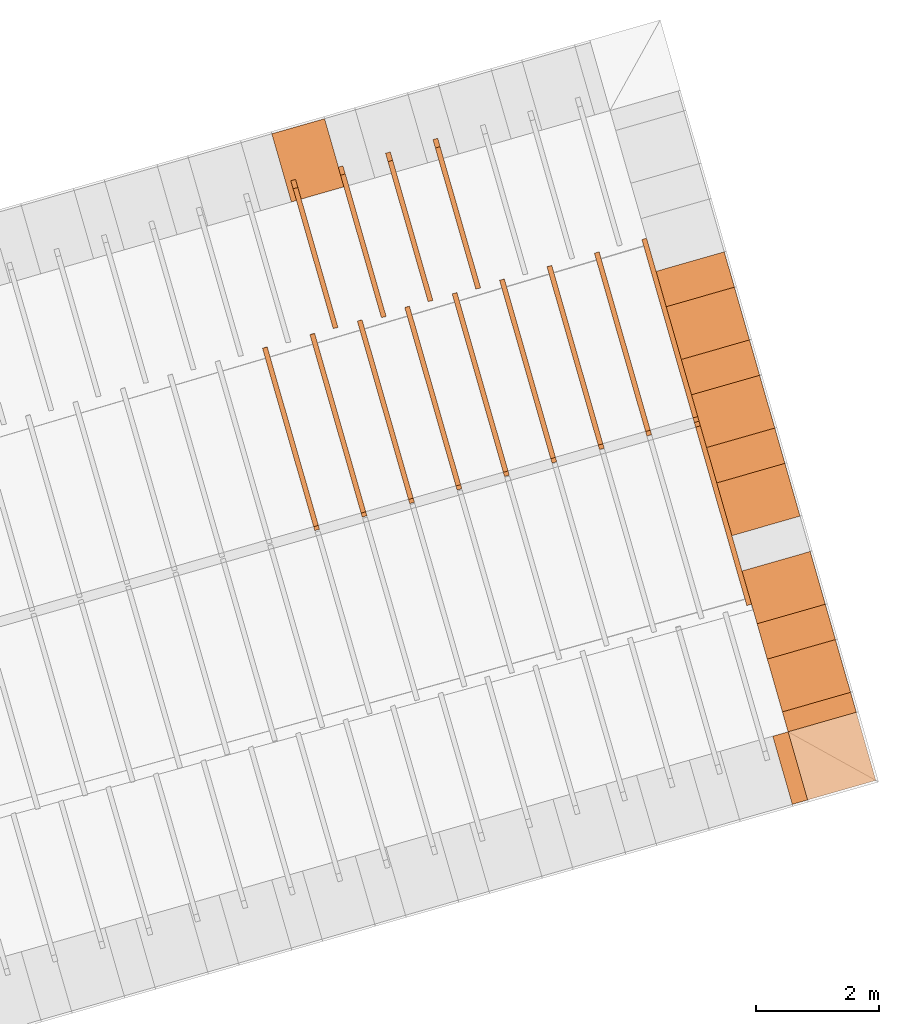
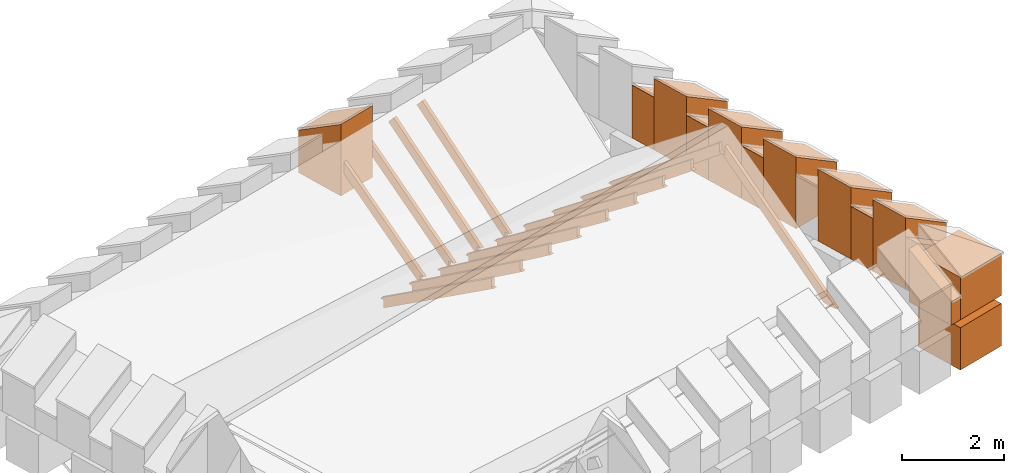
# One storey, part 9 of 10: 28 proxies.
"""IFC4 building model written with IfcOpenShell, lengths in metres."""

from ifc_helpers import new_model, entity, si_unit, converted_unit, derived_unit, direction, frame, origin_with_axes, place, context, subcontext, project, spatial, polygons, material, type_object, element, save


model = new_model("IFC4")

# Units and contexts
model_context = context("Model", 3, precision=1e-05, world=origin_with_axes(), true_north=direction((0.0, 1.0)))
body_context = subcontext(model_context, "Body", "Model", "MODEL_VIEW")
ifc_project = project(units=[si_unit("LENGTHUNIT", "METRE"), si_unit("AREAUNIT", "SQUARE_METRE"), si_unit("VOLUMEUNIT", "CUBIC_METRE"), converted_unit("PLANEANGLEUNIT", "DEGREE", entity("IfcPlaneAngleMeasure", 0.0174532925199433), si_unit("PLANEANGLEUNIT", "RADIAN"), dimensions=[0, 0, 0, 0, 0, 0, 0]), converted_unit("TIMEUNIT", "Year", entity("IfcTimeMeasure", 31557600.0), si_unit("TIMEUNIT", "SECOND"), dimensions=[0, 0, 1, 0, 0, 0, 0]), si_unit("MASSUNIT", "GRAM", prefix="KILO"), si_unit("THERMODYNAMICTEMPERATUREUNIT", "DEGREE_CELSIUS"), si_unit("LUMINOUSINTENSITYUNIT", "LUMEN"), si_unit("ENERGYUNIT", "JOULE", prefix="MEGA"), derived_unit("THERMALCONDUCTANCEUNIT", [(si_unit("POWERUNIT", "WATT"), 1), (si_unit("LENGTHUNIT", "METRE"), -1), (si_unit("THERMODYNAMICTEMPERATUREUNIT", "KELVIN"), -1)]), derived_unit("SPECIFICHEATCAPACITYUNIT", [(si_unit("ENERGYUNIT", "JOULE"), 1), (si_unit("MASSUNIT", "GRAM", prefix="KILO"), -1), (si_unit("THERMODYNAMICTEMPERATUREUNIT", "KELVIN"), -1)]), derived_unit("MASSDENSITYUNIT", [(si_unit("MASSUNIT", "GRAM", prefix="KILO"), 1), (si_unit("VOLUMEUNIT", "CUBIC_METRE"), -1)])], contexts=[model_context])

# Site, building, storey
site_placement = place(None, frame((0.0, 0.0, 0.0), z_axis=(0.0, 0.0, 1.0), x_axis=(0.9612616959383189, 0.2756373558169991, 0.0)))
site = spatial("IfcSite", under=ifc_project, at=site_placement, CompositionType="ELEMENT")
building_placement = place(site_placement, origin_with_axes())
building = spatial("IfcBuilding", under=site, at=building_placement, CompositionType="ELEMENT")
storey_placement = place(building_placement, frame((0.0, 0.0, 11.0), z_axis=(0.0, 0.0, 1.0), x_axis=(1.0, 0.0, 0.0)))
storey = spatial("IfcBuildingStorey", under=building, at=storey_placement, Name="Dach", CompositionType="ELEMENT", Elevation=11.0)

# Proxies
ifc_material_1 = material()
building_element_proxy_type_1 = type_object("IfcBuildingElementProxyType", PredefinedType="NOTDEFINED")
proxy_1_placement = place(storey_placement, frame((-32.67063236374476, 25.87969375484247, -11.3285), z_axis=(0.0, 0.0, 1.0), x_axis=(-1.0, 0.0, 0.0)))
element("IfcBuildingElementProxy", 1, at=proxy_1_placement, inside=storey, type_object=building_element_proxy_type_1, material=ifc_material_1, Name="008", PredefinedType="NOTDEFINED", context=body_context, shape_type="Tessellation", body=[
    polygons([(-57.83241932296884, 7.390572951635179, 12.28518703684454), (-57.83241932296884, 9.787341089745905, 10.39696107503057), (-57.83241932296884, 9.787341089745905, 10.60205325203643), (-57.83241932296884, 9.882514153140576, 10.60205325203643), (-57.83241932296884, 7.526718754969064, 12.458), (-57.91241932296884, 7.390572951635179, 12.28518703684454), (-57.91241932296884, 9.787341089745905, 10.39696107503057), (-57.91241932296884, 9.787341089745905, 10.59617545422803), (-57.91241932296884, 9.889974975517944, 10.59617545422803), (-57.91241932296884, 7.526718754969064, 12.458)], [[[1, 2, 3, 4, 5]], [[1, 6, 7, 2]], [[2, 7, 8, 3]], [[3, 8, 9, 4]], [[4, 9, 10, 5]], [[5, 10, 6, 1]], [[6, 10, 9, 8, 7]]], closed=True),
])
proxy_2_placement = place(storey_placement, frame((-32.67063236374476, 25.87969375484247, -11.3285), z_axis=(0.0, 0.0, 1.0), x_axis=(-1.0, 0.0, 0.0)))
element("IfcBuildingElementProxy", 2, at=proxy_2_placement, inside=storey, type_object=building_element_proxy_type_1, material=ifc_material_1, Name="008", PredefinedType="NOTDEFINED", context=body_context, shape_type="Tessellation", body=[
    polygons([(-58.63241932296884, 7.389549320189349, 12.28599841232647), (-58.63241932296884, 9.787341089745905, 10.37378500663502), (-58.63241932296884, 9.787341089745905, 10.54327527395242), (-58.63241932296884, 9.9276595576109, 10.54327527395242), (-58.63241932296884, 7.526718754969065, 12.458), (-58.71241932296884, 7.389549320189349, 12.28599841232647), (-58.71241932296884, 9.787341089745905, 10.37378500663502), (-58.71241932296884, 9.787341089745905, 10.53739747614402), (-58.71241932296884, 9.935029935397266, 10.53739747614402), (-58.71241932296884, 7.526718754969065, 12.458)], [[[1, 2, 3, 4, 5]], [[1, 6, 7, 2]], [[2, 7, 8, 3]], [[3, 8, 9, 4]], [[4, 9, 10, 5]], [[5, 10, 6, 1]], [[10, 9, 8, 7, 6]]], closed=True),
])
proxy_3_placement = place(storey_placement, frame((-32.67063236374476, 25.87969375484247, -11.3285), z_axis=(0.0, 0.0, 1.0), x_axis=(-1.0, 0.0, 0.0)))
element("IfcBuildingElementProxy", 3, at=proxy_3_placement, inside=storey, type_object=building_element_proxy_type_1, material=ifc_material_1, Name="008", PredefinedType="NOTDEFINED", context=body_context, shape_type="Tessellation", body=[
    polygons([(-59.43241932296884, 7.385575854858428, 12.28924372086243), (-59.43241932296885, 9.787341089745906, 10.28047632939507), (-59.43241932296885, 9.787341089745905, 10.48449729586842), (-59.43241932296884, 9.886320073605198, 10.48449729586842), (-59.43241932296884, 7.526718754969064, 12.458), (-59.51241932296884, 7.385575854858428, 12.28924372086243), (-59.51241932296885, 9.787341089745906, 10.28047632939507), (-59.51241932296885, 9.787341089745905, 10.47861949806002), (-59.51241932296884, 9.893347811358149, 10.47861949806002), (-59.51241932296884, 7.526718754969064, 12.458)], [[[1, 2, 3, 4, 5]], [[1, 6, 7, 2]], [[2, 7, 8, 3]], [[3, 8, 9, 4]], [[4, 9, 10, 5]], [[5, 10, 6, 1]], [[6, 10, 9, 8, 7]]], closed=True),
])
proxy_4_placement = place(storey_placement, frame((-32.67063236374476, 25.87969375484247, -11.3285), z_axis=(0.0, 0.0, 1.0), x_axis=(-1.0, 0.0, 0.0)))
element("IfcBuildingElementProxy", 4, at=proxy_4_placement, inside=storey, type_object=building_element_proxy_type_1, material=ifc_material_1, Name="008", PredefinedType="NOTDEFINED", context=body_context, shape_type="Tessellation", body=[
    polygons([(-60.23241932296884, 7.383753791211458, 12.29078451286503), (-60.23241932296884, 9.787341089745906, 10.23577886170872), (-60.23241932296884, 9.787341089745906, 10.42571931778442), (-60.23241932296884, 9.903726347177741, 10.42571931778442), (-60.23241932296884, 7.526718754969066, 12.458), (-60.31241932296884, 7.383753791211458, 12.29078451286503), (-60.31241932296884, 9.787341089745906, 10.23577886170872), (-60.31241932296884, 9.787341089745906, 10.41984151997602), (-60.31241932296884, 9.910601170197168, 10.41984151997602), (-60.31241932296884, 7.526718754969066, 12.458)], [[[1, 2, 3, 4, 5]], [[1, 6, 7, 2]], [[2, 7, 8, 3]], [[3, 8, 9, 4]], [[4, 9, 10, 5]], [[5, 10, 6, 1]], [[6, 10, 9, 8, 7]]], closed=True),
])
proxy_5_placement = place(storey_placement, frame((79.48385070717022, 25.8856182236699, -11.3285), z_axis=(0.0, 0.0, 1.0), x_axis=(-1.0, 0.0, 0.0)))
element("IfcBuildingElementProxy", 5, at=proxy_5_placement, inside=storey, type_object=building_element_proxy_type_1, material=ifc_material_1, Name="003", PredefinedType="NOTDEFINED", context=body_context, shape_type="Tessellation", body=[
    polygons([(49.03241932244962, 15.9873410897459, 10.213), (49.03241932244962, 15.72809666023682, 10.213), (49.03241932244962, 12.96959440049846, 12.42240354413239), (49.03241932244962, 13.0473410897459, 12.42240354413239), (49.03241932244962, 13.0473410897459, 12.642), (49.03241932244962, 16.05704587116515, 10.23139751186164), (49.03241932244962, 16.05711434511866, 10.21343617721011), (49.03241932244962, 15.9873410897459, 10.21343617721011), (49.11241932244962, 15.72809666023682, 10.213), (49.11241932244968, 15.9873410897459, 10.213), (49.11241932244962, 12.96959440049846, 12.42240354413239), (49.11241932244962, 13.0473410897459, 12.42240354413239), (49.11241932244962, 13.0473410897459, 12.642), (49.11241932244962, 16.05704587116515, 10.23139751186164), (49.11241932244962, 16.05709193720401, 10.21931397501851), (49.11241932244968, 15.9873410897459, 10.21931397501852)], [[[1, 2, 3, 4, 5, 6, 7, 8]], [[9, 2, 1, 10]], [[2, 9, 11, 3]], [[12, 4, 3, 11]], [[13, 5, 4, 12]], [[6, 5, 13, 14]], [[7, 6, 14, 15]], [[8, 7, 15, 16]], [[1, 8, 16, 10]], [[10, 16, 15, 14, 13, 12, 11, 9]]], closed=True),
])
proxy_6_placement = place(storey_placement, frame((79.48385070717022, -0.05357057732701342, -11.3285), z_axis=(0.0, 0.0, 1.0), x_axis=(1.0, 0.0, 0.0)))
element("IfcBuildingElementProxy", 6, at=proxy_6_placement, inside=storey, type_object=building_element_proxy_type_1, material=ifc_material_1, Name="003", PredefinedType="NOTDEFINED", context=body_context, shape_type="Tessellation", body=[
    polygons([(-55.43241932244963, 13.0473410897459, 12.42240354413239), (-55.43241932244962, 12.98223842714421, 12.42240354413239), (-55.43241932244962, 15.9873410897459, 10.49556478084415), (-55.43241932244962, 15.9873410897459, 10.68366000188212), (-55.43241932244962, 16.06016943486015, 10.68366000188212), (-55.43241932244962, 16.05704587116529, 10.71221040876106), (-55.43241932244962, 13.0473410897459, 12.642), (-55.51241932244962, 13.0473410897459, 12.42240354413239), (-55.51241932244962, 12.98223842714421, 12.42240354413239), (-55.51241932244962, 15.9873410897459, 10.49556478084415), (-55.51241932244965, 15.9873410897459, 10.68953779969052), (-55.51241932244962, 16.05952637306709, 10.68953779969052), (-55.51241932244962, 16.05704587116529, 10.71221040876106), (-55.51241932244962, 13.0473410897459, 12.642)], [[[1, 2, 3, 4, 5, 6, 7]], [[1, 8, 9, 2]], [[3, 2, 9, 10]], [[3, 10, 11, 4]], [[4, 11, 12, 5]], [[5, 12, 13, 6]], [[6, 13, 14, 7]], [[7, 14, 8, 1]], [[13, 12, 11, 10, 9, 8, 14]]], closed=True),
])
proxy_7_placement = place(storey_placement, frame((79.48385070717022, -0.05357057732701342, -11.3285), z_axis=(0.0, 0.0, 1.0), x_axis=(1.0, 0.0, 0.0)))
element("IfcBuildingElementProxy", 7, at=proxy_7_placement, inside=storey, type_object=building_element_proxy_type_1, material=ifc_material_1, Name="003", PredefinedType="NOTDEFINED", context=body_context, shape_type="Tessellation", body=[
    polygons([(-54.63241932244966, 13.0473410897459, 12.42240354413239), (-54.63241932244962, 12.98074433194067, 12.42240354413239), (-54.63241932244962, 15.9873410897459, 10.440588075492), (-54.63241932244962, 15.9873410897459, 10.62488202379812), (-54.63241932244962, 16.06025960763651, 10.62488202379812), (-54.63241932244962, 16.05704587116528, 10.65813585979772), (-54.63241932244962, 13.0473410897459, 12.642), (-54.71241932244962, 13.0473410897459, 12.42240354413239), (-54.71241932244962, 12.98074433194067, 12.42240354413239), (-54.71241932244962, 15.9873410897459, 10.440588075492), (-54.71241932244962, 15.9873410897459, 10.63075982160652), (-54.71241932244962, 16.05969156209772, 10.63075982160652), (-54.71241932244962, 16.05704587116528, 10.65813585979772), (-54.71241932244962, 13.0473410897459, 12.642)], [[[1, 2, 3, 4, 5, 6, 7]], [[1, 8, 9, 2]], [[3, 2, 9, 10]], [[3, 10, 11, 4]], [[4, 11, 12, 5]], [[5, 12, 13, 6]], [[6, 13, 14, 7]], [[7, 14, 8, 1]], [[13, 12, 11, 10, 9, 8, 14]]], closed=True),
])
proxy_8_placement = place(storey_placement, frame((79.48385070717022, -0.05357057732701342, -11.3285), z_axis=(0.0, 0.0, 1.0), x_axis=(1.0, 0.0, 0.0)))
element("IfcBuildingElementProxy", 8, at=proxy_8_placement, inside=storey, type_object=building_element_proxy_type_1, material=ifc_material_1, Name="003", PredefinedType="NOTDEFINED", context=body_context, shape_type="Tessellation", body=[
    polygons([(-53.83241932244963, 13.0473410897459, 12.42240354413239), (-53.83241932244962, 12.97866457198798, 12.42240354413239), (-53.83241932244962, 15.9873410897459, 10.36284655167166), (-53.83241932244962, 15.9873410897459, 10.56610404571412), (-53.83241932244962, 16.05828132135308, 10.56610404571412), (-53.83241932244962, 16.05704587116526, 10.58173912076317), (-53.83241932244962, 13.0473410897459, 12.642), (-53.91241932244962, 13.0473410897459, 12.42240354413239), (-53.91241932244962, 12.97866457198798, 12.42240354413239), (-53.91241932244962, 15.9873410897459, 10.36284655167166), (-53.91241932244963, 15.9873410897459, 10.57198184352252), (-53.91241932244962, 16.05781687034254, 10.57198184352252), (-53.91241932244962, 16.05704587116526, 10.58173912076317), (-53.91241932244962, 13.0473410897459, 12.642)], [[[1, 2, 3, 4, 5, 6, 7]], [[1, 8, 9, 2]], [[3, 2, 9, 10]], [[3, 10, 11, 4]], [[4, 11, 12, 5]], [[5, 12, 13, 6]], [[6, 13, 14, 7]], [[7, 14, 8, 1]], [[13, 12, 11, 10, 9, 8, 14]]], closed=True),
])
proxy_9_placement = place(storey_placement, frame((79.48385070717022, -0.05357057732701342, -11.3285), z_axis=(0.0, 0.0, 1.0), x_axis=(1.0, 0.0, 0.0)))
element("IfcBuildingElementProxy", 9, at=proxy_9_placement, inside=storey, type_object=building_element_proxy_type_1, material=ifc_material_1, Name="003", PredefinedType="NOTDEFINED", context=body_context, shape_type="Tessellation", body=[
    polygons([(-53.03241932244962, 15.9873410897459, 10.32102670754271), (-53.03241932244962, 12.97756177222931, 12.42240354413239), (-53.11241932244962, 12.97756177222931, 12.42240354413239), (-53.11241932244962, 15.9873410897459, 10.32102670754271), (-53.03241932244961, 13.0473410897459, 12.42240354413239), (-53.03241932244962, 15.9873410897459, 10.50732606763012), (-53.03241932244962, 16.05937148295102, 10.50732606763012), (-53.03241932244962, 16.05704587116524, 10.54067520324821), (-53.03241932244962, 13.0473410897459, 12.642), (-53.11241932244962, 13.0473410897459, 12.42240354413239), (-53.11241932244962, 16.05704587116524, 10.54067520324821), (-53.11241932244962, 16.05896159299123, 10.51320386543852), (-53.11241932244957, 15.9873410897459, 10.51320386543852), (-53.11241932244962, 13.0473410897459, 12.642)], [[[1, 2, 3, 4]], [[5, 2, 1, 6, 7, 8, 9]], [[5, 10, 3, 2]], [[11, 12, 13, 4, 3, 10, 14]], [[1, 4, 13, 6]], [[6, 13, 12, 7]], [[7, 12, 11, 8]], [[8, 11, 14, 9]], [[9, 14, 10, 5]]], closed=True),
])
proxy_10_placement = place(storey_placement, frame((79.48385070717022, -0.05357057732701342, -11.3285), z_axis=(0.0, 0.0, 1.0), x_axis=(1.0, 0.0, 0.0)))
element("IfcBuildingElementProxy", 10, at=proxy_10_placement, inside=storey, type_object=building_element_proxy_type_1, material=ifc_material_1, Name="003", PredefinedType="NOTDEFINED", context=body_context, shape_type="Tessellation", body=[
    polygons([(-50.63241932244962, 15.9873410897459, 10.213), (-50.63241932244962, 15.9873410897459, 10.33099213337812), (-50.63241932244962, 16.05776782380472, 10.33099213337812), (-50.63241932244962, 16.05704587116519, 10.35550526116538), (-50.63241932244962, 13.0473410897459, 12.642), (-50.63241932244962, 13.0473410897459, 12.42240354413239), (-50.63241932244962, 12.97271999412028, 12.42240354413239), (-50.63241932244962, 15.88094991388374, 10.213), (-50.71241932244963, 15.9873410897459, 10.213), (-50.71241932244963, 15.9873410897459, 10.33686993118652), (-50.71241932244962, 16.05759471282193, 10.33686993118652), (-50.71241932244962, 16.05704587116519, 10.35550526116538), (-50.71241932244962, 13.0473410897459, 12.642), (-50.71241932244962, 13.0473410897459, 12.42240354413239), (-50.71241932244962, 12.97271999412028, 12.42240354413239), (-50.71241932244962, 15.88094991388374, 10.213)], [[[1, 2, 3, 4, 5, 6, 7, 8]], [[1, 9, 10, 2]], [[2, 10, 11, 3]], [[3, 11, 12, 4]], [[4, 12, 13, 5]], [[6, 5, 13, 14]], [[14, 15, 7, 6]], [[8, 7, 15, 16]], [[16, 9, 1, 8]], [[9, 16, 15, 14, 13, 12, 11, 10]]], closed=True),
])
proxy_11_placement = place(storey_placement, frame((79.48385070717022, -0.05357057732701342, -11.3285), z_axis=(0.0, 0.0, 1.0), x_axis=(1.0, 0.0, 0.0)))
element("IfcBuildingElementProxy", 11, at=proxy_11_placement, inside=storey, type_object=building_element_proxy_type_1, material=ifc_material_1, Name="003", PredefinedType="NOTDEFINED", context=body_context, shape_type="Tessellation", body=[
    polygons([(-51.43241932244962, 15.9873410897459, 10.213), (-51.43241932244962, 15.9873410897459, 10.38977011146212), (-51.43241932244962, 16.05835597052995, 10.38977011146212), (-51.43241932244962, 16.05704587116521, 10.4200850782058), (-51.43241932244962, 13.0473410897459, 12.642), (-51.43241932244961, 13.0473410897459, 12.42240354413239), (-51.43241932244962, 12.97438427181221, 12.42240354413239), (-51.43241932244962, 15.96714171073835, 10.213), (-51.51241932244962, 15.9873410897459, 10.213), (-51.5124193224496, 15.9873410897459, 10.39564790927052), (-51.51241932244962, 16.05810195411489, 10.39564790927052), (-51.51241932244962, 16.05704587116521, 10.4200850782058), (-51.51241932244962, 13.0473410897459, 12.642), (-51.51241932244962, 13.0473410897459, 12.42240354413239), (-51.51241932244962, 12.97438427181221, 12.42240354413239), (-51.51241932244962, 15.96714171073835, 10.213)], [[[1, 2, 3, 4, 5, 6, 7, 8]], [[1, 9, 10, 2]], [[2, 10, 11, 3]], [[3, 11, 12, 4]], [[4, 12, 13, 5]], [[6, 5, 13, 14]], [[14, 15, 7, 6]], [[8, 7, 15, 16]], [[16, 9, 1, 8]], [[9, 16, 15, 14, 13, 12, 11, 10]]], closed=True),
])
proxy_12_placement = place(storey_placement, frame((79.48385070717022, -0.05357057732701342, -11.3285), z_axis=(0.0, 0.0, 1.0), x_axis=(1.0, 0.0, 0.0)))
element("IfcBuildingElementProxy", 12, at=proxy_12_placement, inside=storey, type_object=building_element_proxy_type_1, material=ifc_material_1, Name="003", PredefinedType="NOTDEFINED", context=body_context, shape_type="Tessellation", body=[
    polygons([(-49.83241932244962, 15.9873410897459, 10.213), (-49.83241932244962, 15.9873410897459, 10.27221415529412), (-49.83241932244962, 16.05730391812493, 10.27221415529412), (-49.83241932244962, 16.05704587116517, 10.28881510944665), (-49.83241932244962, 13.0473410897459, 12.642), (-49.83241932244954, 13.0473410897459, 12.42240354413239), (-49.83241932244962, 12.97102857594039, 12.42240354413239), (-49.83241932244962, 15.7968381574803, 10.213), (-49.91241932244963, 15.9873410897459, 10.213), (-49.91241932244964, 15.9873410897459, 10.27809195310252), (-49.91241932244962, 16.05721255302382, 10.27809195310251), (-49.91241932244962, 16.05704587116517, 10.28881510944665), (-49.91241932244962, 13.0473410897459, 12.642), (-49.91241932244962, 13.0473410897459, 12.42240354413239), (-49.91241932244962, 12.97102857594039, 12.42240354413239), (-49.91241932244962, 15.7968381574803, 10.213)], [[[1, 2, 3, 4, 5, 6, 7, 8]], [[1, 9, 10, 2]], [[2, 10, 11, 3]], [[3, 11, 12, 4]], [[4, 12, 13, 5]], [[13, 14, 6, 5]], [[14, 15, 7, 6]], [[8, 7, 15, 16]], [[16, 9, 1, 8]], [[9, 16, 15, 14, 13, 12, 11, 10]]], closed=True),
])
proxy_13_placement = place(storey_placement, frame((79.48385070717022, -0.05357057732701342, -11.3285), z_axis=(0.0, 0.0, 1.0), x_axis=(1.0, 0.0, 0.0)))
element("IfcBuildingElementProxy", 13, at=proxy_13_placement, inside=storey, type_object=building_element_proxy_type_1, material=ifc_material_1, Name="003", PredefinedType="NOTDEFINED", context=body_context, shape_type="Tessellation", body=[
    polygons([(-52.23241932244962, 15.9873410897459, 10.24879059796566), (-52.23241932244962, 12.97568312696457, 12.42240354413239), (-52.31241932244962, 12.97568312696457, 12.42240354413239), (-52.31241932244962, 15.9873410897459, 10.24879059796566), (-52.23241932244967, 13.0473410897459, 12.42240354413239), (-52.23241932244962, 15.9873410897459, 10.44854808954612), (-52.23241932244962, 16.05819366012707, 10.44854808954612), (-52.23241932244962, 16.05704587116523, 10.46979672928334), (-52.23241932244962, 13.0473410897459, 12.642), (-52.31241932244962, 13.0473410897459, 12.42240354413239), (-52.31241932244962, 16.05704587116523, 10.46979672928334), (-52.31241932244962, 16.05787615879391, 10.45442588735452), (-52.31241932244964, 15.9873410897459, 10.45442588735452), (-52.31241932244962, 13.0473410897459, 12.642)], [[[1, 2, 3, 4]], [[5, 2, 1, 6, 7, 8, 9]], [[5, 10, 3, 2]], [[11, 12, 13, 4, 3, 10, 14]], [[1, 4, 13, 6]], [[6, 13, 12, 7]], [[7, 12, 11, 8]], [[8, 11, 14, 9]], [[9, 14, 10, 5]]], closed=True),
])
proxy_14_placement = place(storey_placement, frame((79.48385070717022, -0.05357057732701342, -11.3285), z_axis=(0.0, 0.0, 1.0), x_axis=(1.0, 0.0, 0.0)))
element("IfcBuildingElementProxy", 14, at=proxy_14_placement, inside=storey, type_object=building_element_proxy_type_1, material=ifc_material_1, Name="003", PredefinedType="NOTDEFINED", context=body_context, shape_type="Tessellation", body=[
    polygons([(-49.03241932244962, 15.9873410897459, 10.213), (-49.03241932244962, 15.9873410897459, 10.21343617721011), (-49.03241932244962, 16.05711434511866, 10.21343617721011), (-49.03241932244962, 16.05704587116515, 10.23139751186164), (-49.03241932244962, 13.0473410897459, 12.642), (-49.03241932244962, 13.0473410897459, 12.42240354413239), (-49.03241932244962, 12.96959440049846, 12.42240354413239), (-49.03241932244962, 15.72809666023682, 10.213), (-49.11241932244968, 15.9873410897459, 10.213), (-49.11241932244968, 15.9873410897459, 10.21931397501852), (-49.11241932244962, 16.05709193720401, 10.21931397501851), (-49.11241932244962, 16.05704587116515, 10.23139751186164), (-49.11241932244962, 13.0473410897459, 12.642), (-49.11241932244962, 13.0473410897459, 12.42240354413239), (-49.11241932244962, 12.96959440049846, 12.42240354413239), (-49.11241932244962, 15.72809666023682, 10.213)], [[[1, 2, 3, 4, 5, 6, 7, 8]], [[1, 9, 10, 2]], [[2, 10, 11, 3]], [[3, 11, 12, 4]], [[4, 12, 13, 5]], [[13, 14, 6, 5]], [[14, 15, 7, 6]], [[8, 7, 15, 16]], [[16, 9, 1, 8]], [[9, 16, 15, 14, 13, 12, 11, 10]]], closed=True),
])
ifc_material_2 = material()
building_element_proxy_type_2 = type_object("IfcBuildingElementProxyType", Name="336 x 1150", PredefinedType="NOTDEFINED")
proxy_15_placement = place(storey_placement, frame((31.02643138169893, 7.843604233070339, 0.2019994043252051), z_axis=(0.0, 0.0, 1.0), x_axis=(0.0, 1.0, 0.0)))
element("IfcBuildingElementProxy", 15, at=proxy_15_placement, inside=storey, type_object=building_element_proxy_type_2, material=ifc_material_2, PredefinedType="NOTDEFINED", context=body_context, shape_type="Tessellation", body=[
    polygons([(-0.168202742070406, -0.5749999999999993, 0.5616599571312832), (-0.168202742070406, -0.5749999999999993, 0.0), (0.168202742070406, -0.5749999999999993, 0.0), (0.168202742070406, -0.5749999999999993, 0.5616599571312832), (-0.168202742070406, 0.5749999999999993, 1.258340042868717), (-0.168202742070406, 0.5749999999999993, 0.0), (0.168202742070406, 0.5749999999999993, 0.0), (0.168202742070406, 0.5749999999999993, 1.258340042868717)], [[[1, 2, 3, 4]], [[5, 6, 2, 1]], [[3, 2, 6, 7]], [[4, 3, 7, 8]], [[5, 1, 4, 8]], [[8, 7, 6, 5]]], closed=True),
])
building_element_proxy_type_3 = type_object("IfcBuildingElementProxyType", Name="259 x 1150", PredefinedType="NOTDEFINED")
proxy_16_placement = place(storey_placement, frame((30.32195057983162, 7.100401490534706, 0.2019994110307355), z_axis=(0.0, 0.0, 1.0), x_axis=(1.0, 0.0, 0.0)))
element("IfcBuildingElementProxy", 16, at=proxy_16_placement, inside=storey, type_object=building_element_proxy_type_3, material=ifc_material_2, PredefinedType="NOTDEFINED", context=body_context, shape_type="Tessellation", body=[
    polygons([(-0.1294808085213468, -0.5749999999999993, 0.5616599571312832), (-0.1294808085213468, -0.5749999999999993, 0.0), (0.1294808085213504, -0.5749999999999993, 0.0), (0.1294808085213504, -0.5749999999999993, 0.5616599571312832), (-0.1294808085213468, 0.5750000000000002, 1.258340042868717), (-0.1294808085213468, 0.5750000000000002, 0.0), (0.1294808085213504, 0.5750000000000002, 0.0), (0.1294808085213504, 0.5750000000000002, 1.258340042868717)], [[[1, 2, 3, 4]], [[5, 6, 2, 1]], [[3, 2, 6, 7]], [[4, 3, 7, 8]], [[5, 1, 4, 8]], [[8, 7, 6, 5]]], closed=True),
])
building_element_proxy_type_4 = type_object("IfcBuildingElementProxyType", Name="1150 x 1150", PredefinedType="NOTDEFINED")
proxy_17_placement = place(storey_placement, frame((31.02643138835295, 7.100401490534724, 0.2019994110307373), z_axis=(0.0, 0.0, 1.0), x_axis=(0.0, 1.0, 0.0)))
element("IfcBuildingElementProxy", 17, at=proxy_17_placement, inside=storey, type_object=building_element_proxy_type_4, material=ifc_material_2, PredefinedType="NOTDEFINED", context=body_context, shape_type="Tessellation", body=[
    polygons([(-0.5750000000000011, -0.5749999999999993, 1.011699999999999), (-0.5750000000000011, -0.5749999999999993, 0.0), (0.5749999999999993, -0.5749999999999993, 0.0), (0.5749999999999993, -0.5749999999999993, 1.011699999999999), (-0.5750000000000002, 0.5749999999999993, 1.011699999999999), (-0.5750000000000002, 0.5749999999999993, 0.0), (0.5750000000000002, 0.5749999999999993, 0.0), (0.5750000000000002, 0.5749999999999993, 1.011699999999999)], [[[1, 2, 3, 4]], [[5, 6, 2, 1]], [[3, 2, 6, 7]], [[4, 3, 7, 8]], [[5, 1, 4, 8]], [[8, 7, 6, 5]]], closed=True),
])
building_element_proxy_type_5 = type_object("IfcBuildingElementProxyType", Name="596 x 1150", PredefinedType="NOTDEFINED")
proxy_18_placement = place(storey_placement, frame((31.02643138444818, 15.14563253431009, 0.2019994076779685), z_axis=(0.0, 0.0, 1.0), x_axis=(0.0, 1.0, 0.0)))
element("IfcBuildingElementProxy", 18, at=proxy_18_placement, inside=storey, type_object=building_element_proxy_type_5, material=ifc_material_2, PredefinedType="NOTDEFINED", context=body_context, shape_type="Tessellation", body=[
    polygons([(-0.2981999999999996, -0.5749999999999993, 0.5616599571312832), (-0.2981999999999996, -0.5749999999999993, 0.0), (0.2981999999999996, -0.5749999999999993, 0.0), (0.2981999999999996, -0.5749999999999993, 0.5616599571312832), (-0.2981999999999996, 0.5749999999999993, 1.258340042868717), (-0.2981999999999996, 0.5749999999999993, 0.0), (0.2981999999999996, 0.5749999999999993, 0.0), (0.2981999999999996, 0.5749999999999993, 1.258340042868717)], [[[1, 2, 3, 4]], [[5, 6, 2, 1]], [[3, 2, 6, 7]], [[4, 3, 7, 8]], [[5, 1, 4, 8]], [[8, 7, 6, 5]]], closed=True),
])
proxy_19_placement = place(storey_placement, frame((31.02643138462979, 13.65922672876636, 0.2019994076779685), z_axis=(0.0, 0.0, 1.0), x_axis=(0.0, 1.0, 0.0)))
element("IfcBuildingElementProxy", 19, at=proxy_19_placement, inside=storey, type_object=building_element_proxy_type_5, material=ifc_material_2, PredefinedType="NOTDEFINED", context=body_context, shape_type="Tessellation", body=[
    polygons([(-0.2981999999999996, -0.5749999999999993, 0.5616599571312832), (-0.2981999999999996, -0.5749999999999993, 0.0), (0.2981999999999996, -0.5750000000000028, 0.0), (0.2981999999999996, -0.5750000000000028, 0.5616599571312832), (-0.2981999999999996, 0.5749999999999993, 1.258340042868717), (-0.2981999999999996, 0.5749999999999993, 0.0), (0.2981999999999996, 0.5749999999999957, 0.0), (0.2981999999999996, 0.5749999999999957, 1.258340042868717)], [[[1, 2, 3, 4]], [[5, 6, 2, 1]], [[3, 2, 6, 7]], [[4, 3, 7, 8]], [[5, 1, 4, 8]], [[8, 7, 6, 5]]], closed=True),
])
for number, where, z_axis, x_axis in (
    (20, (31.0264313848114, 12.17282092322263, 0.2019994076779685), (0.0, 0.0, 1.0), (0.0, 1.0, 0.0)),
    (21, (31.02643138517462, 9.200009312135167, 0.2019994076779685), (0.0, 0.0, 1.0), (0.0, 1.0, 0.0)),
):
    element("IfcBuildingElementProxy", number, at=place(storey_placement, frame(where, z_axis=z_axis, x_axis=x_axis)), inside=storey, type_object=building_element_proxy_type_5, material=ifc_material_2, PredefinedType="NOTDEFINED", context=body_context, shape_type="Tessellation", body=[
        polygons([(-0.2981999999999996, -0.5749999999999993, 0.5616599571312832), (-0.2981999999999996, -0.5749999999999993, 0.0), (0.2981999999999996, -0.5749999999999993, 0.0), (0.2981999999999996, -0.5749999999999993, 0.5616599571312832), (-0.2981999999999996, 0.5749999999999993, 1.258340042868717), (-0.2981999999999996, 0.5749999999999993, 0.0), (0.2981999999999996, 0.5749999999999993, 0.0), (0.2981999999999996, 0.5749999999999993, 1.258340042868717)], [[[1, 2, 3, 4]], [[5, 6, 2, 1]], [[3, 2, 6, 7]], [[4, 3, 7, 8]], [[5, 1, 4, 8]], [[8, 7, 6, 5]]], closed=True),
    ])
building_element_proxy_type_6 = type_object("IfcBuildingElementProxyType", Name="890 x 1150", PredefinedType="NOTDEFINED")
proxy_20_placement = place(storey_placement, frame((31.02643138456925, 14.40242909089679, 0.2019994076779703), z_axis=(0.0, 0.0, 1.0), x_axis=(0.0, 1.0, 0.0)))
element("IfcBuildingElementProxy", 22, at=proxy_20_placement, inside=storey, type_object=building_element_proxy_type_6, material=ifc_material_2, PredefinedType="NOTDEFINED", context=body_context, shape_type="Tessellation", body=[
    polygons([(-0.4450012808476238, -0.5750000000000028, 1.011659957131281), (-0.4450012808476238, -0.5750000000000028, 0.0), (0.4450012808476256, -0.5750000000000028, 0.0), (0.4450012808476256, -0.5750000000000028, 1.011659957131281), (-0.4450012808476238, 0.5749999999999993, 1.708340042868716), (-0.4450012808476238, 0.5749999999999993, 0.0), (0.4450012808476256, 0.5749999999999993, 0.0), (0.4450012808476256, 0.5749999999999993, 1.708340042868716)], [[[1, 2, 3, 4]], [[5, 6, 2, 1]], [[3, 2, 6, 7]], [[4, 3, 7, 8]], [[5, 1, 4, 8]], [[8, 7, 6, 5]]], closed=True),
])
for number, where, z_axis, x_axis in (
    (23, (31.02643138487194, 11.42961856109216, 0.2019994076779703), (0.0, 0.0, 1.0), (0.0, 1.0, 0.0)),
    (24, (31.0264313847206, 12.91602382599448, 0.2019994076779703), (0.0, 0.0, 1.0), (0.0, 1.0, 0.0)),
):
    element("IfcBuildingElementProxy", number, at=place(storey_placement, frame(where, z_axis=z_axis, x_axis=x_axis)), inside=storey, type_object=building_element_proxy_type_6, material=ifc_material_2, PredefinedType="NOTDEFINED", context=body_context, shape_type="Tessellation", body=[
        polygons([(-0.4450012808476238, -0.5749999999999993, 1.011659957131286), (-0.4450012808476238, -0.5749999999999993, 0.0), (0.4450012808476256, -0.5750000000000028, 0.0), (0.4450012808476256, -0.5750000000000028, 1.011659957131286), (-0.4450012808476238, 0.5750000000000028, 1.70834004286872), (-0.4450012808476238, 0.5750000000000028, 0.0), (0.4450012808476256, 0.5749999999999993, 0.0), (0.4450012808476256, 0.5749999999999993, 1.70834004286872)], [[[1, 2, 3, 4]], [[5, 6, 2, 1]], [[3, 2, 6, 7]], [[4, 3, 7, 8]], [[5, 1, 4, 8]], [[8, 7, 6, 5]]], closed=True),
    ])
proxy_21_placement = place(storey_placement, frame((31.02643138502329, 9.943213296189844, 0.2019994076779703), z_axis=(0.0, 0.0, 1.0), x_axis=(0.0, 1.0, 0.0)))
element("IfcBuildingElementProxy", 25, at=proxy_21_placement, inside=storey, type_object=building_element_proxy_type_6, material=ifc_material_2, PredefinedType="NOTDEFINED", context=body_context, shape_type="Tessellation", body=[
    polygons([(-0.4450012808476238, -0.5750000000000028, 1.011659957131281), (-0.4450012808476238, -0.5750000000000028, 0.0), (0.4450012808476256, -0.5750000000000028, 0.0), (0.4450012808476256, -0.5750000000000028, 1.011659957131281), (-0.4450012808476238, 0.5749999999999993, 1.708340042868716), (-0.4450012808476238, 0.5749999999999993, 0.0), (0.4450012808476256, 0.5749999999999993, 0.0), (0.4450012808476256, 0.5749999999999993, 1.708340042868716)], [[[1, 2, 3, 4]], [[5, 6, 2, 1]], [[3, 2, 6, 7]], [[4, 3, 7, 8]], [[5, 1, 4, 8]], [[8, 7, 6, 5]]], closed=True),
])
proxy_22_placement = place(storey_placement, frame((25.52058676035336, 18.7316461534199, 0.2019994076779703), z_axis=(0.0, 0.0, 1.0), x_axis=(-1.0, -4.202208037436403e-09, 0.0)))
element("IfcBuildingElementProxy", 26, at=proxy_22_placement, inside=storey, type_object=building_element_proxy_type_6, material=ifc_material_2, PredefinedType="NOTDEFINED", context=body_context, shape_type="Tessellation", body=[
    polygons([(0.4450012808476238, 0.5749999999999993, 1.70834004286872), (0.4450012808476238, 0.5749999999999993, 0.0), (-0.4450012808476274, 0.5749999999999993, 0.0), (-0.4450012808476274, 0.5749999999999993, 1.70834004286872), (0.4450012808476238, -0.5749999999999993, 1.011659957131286), (0.4450012808476238, -0.5749999999999993, 0.0), (-0.4450012808476274, -0.5749999999999993, 0.0), (-0.4450012808476274, -0.5749999999999993, 1.011659957131286)], [[[1, 2, 3, 4]], [[5, 6, 2, 1]], [[3, 2, 6, 7]], [[4, 3, 7, 8]], [[5, 1, 4, 8]], [[8, 7, 6, 5]]], closed=True),
])
proxy_23_placement = place(storey_placement, frame((31.02643138517463, 8.456808031287528, 0.2019994076779703), z_axis=(0.0, 0.0, 1.0), x_axis=(0.0, 1.0, 0.0)))
element("IfcBuildingElementProxy", 27, at=proxy_23_placement, inside=storey, type_object=building_element_proxy_type_6, material=ifc_material_2, PredefinedType="NOTDEFINED", context=body_context, shape_type="Tessellation", body=[
    polygons([(-0.4450012808476238, -0.5749999999999993, 1.011659957131281), (-0.4450012808476238, -0.5749999999999993, 0.0), (0.4450012808476256, -0.5750000000000028, 0.0), (0.4450012808476256, -0.5750000000000028, 1.011659957131281), (-0.4450012808476238, 0.5750000000000028, 1.708340042868716), (-0.4450012808476238, 0.5750000000000028, 0.0), (0.4450012808476256, 0.5749999999999993, 0.0), (0.4450012808476256, 0.5749999999999993, 1.708340042868716)], [[[1, 2, 3, 4]], [[5, 6, 2, 1]], [[3, 2, 6, 7]], [[4, 3, 7, 8]], [[5, 1, 4, 8]], [[8, 7, 6, 5]]], closed=True),
])
building_element_proxy_type_7 = type_object("IfcBuildingElementProxyType", PredefinedType="NOTDEFINED")
proxy_24_placement = place(storey_placement, frame((0.0, 0.0, -31.0), z_axis=(0.0, 0.0, 1.0), x_axis=(1.0, 0.0, 0.0)))
element("IfcBuildingElementProxy", 28, at=proxy_24_placement, inside=storey, type_object=building_element_proxy_type_7, material=ifc_material_2, PredefinedType="NOTDEFINED", context=body_context, shape_type="Tessellation", body=[
    polygons([(30.45143138411522, 6.525401490534714, 30.0), (30.45143138411518, 7.675401490534714, 30.0), (31.60143138411518, 7.675401490534748, 30.0), (31.60143138411522, 6.525401490534747, 30.0), (30.45143138411522, 6.525401490534714, 31.0117), (30.45143138411518, 7.675401490534714, 31.0117), (31.60143138411518, 7.675401490534748, 31.0117), (31.60143138411522, 6.525401490534747, 31.0117)], [[[1, 2, 3, 4]], [[1, 5, 6, 2]], [[2, 6, 7, 3]], [[4, 3, 7, 8]], [[5, 1, 4, 8]], [[5, 8, 7, 6]]], closed=True),
])

save(model, "model.ifc")
